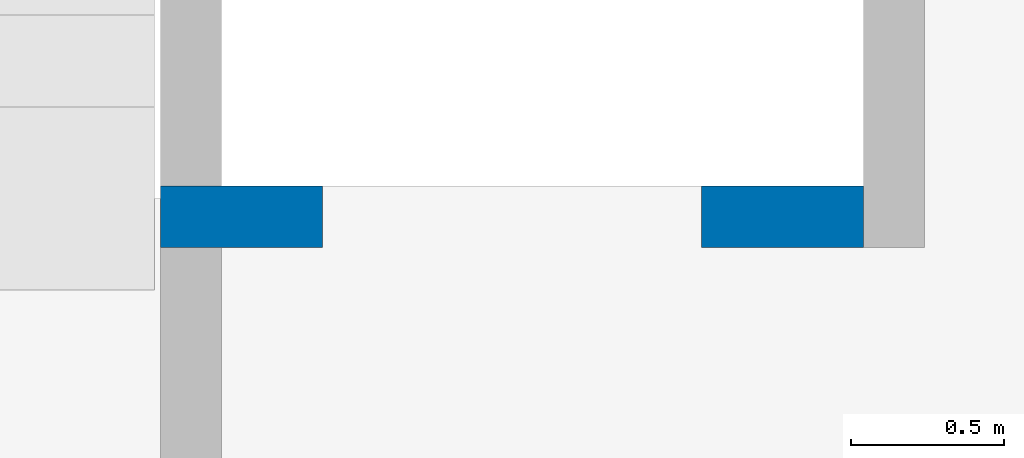
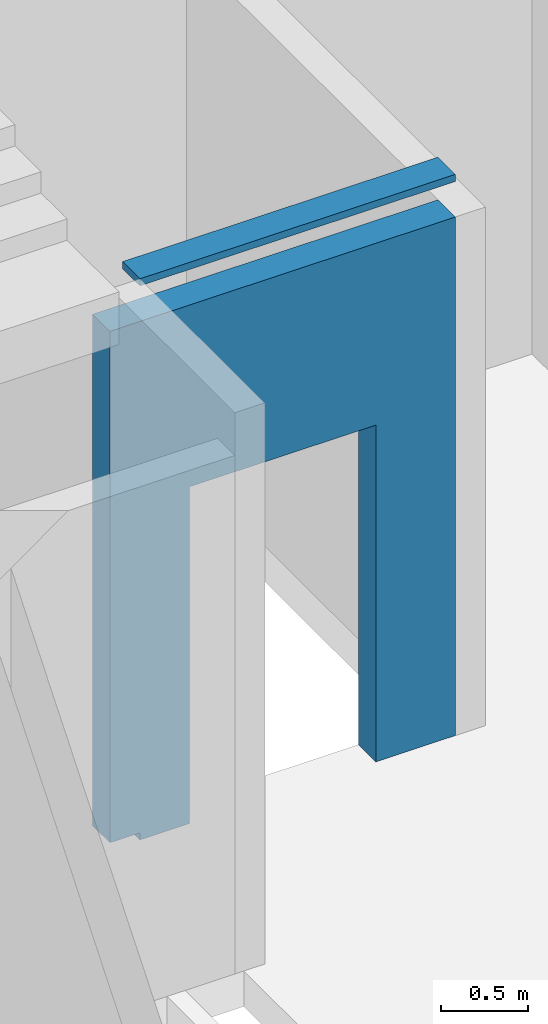
# One storey, part 93 of 93: 1 wall, 1 opening.
"""IFC4 building model written with IfcOpenShell, lengths in millimetres."""

from ifc_helpers import new_model, entity, si_unit, converted_unit, derived_unit, direction, frame, origin, place, context, subcontext, project, spatial, indexed_curve, outline, extrude, polygons, material, type_object, element, save


model = new_model("IFC4")

# Units and contexts
model_context = context("Model", 3, precision=0.01, world=origin(), true_north=direction((6.12303176911189e-17, 1.0)))
plan_context = context("Plan", 3, precision=0.01, world=origin(), true_north=direction((6.12303176911189e-17, 1.0)))
body_context = subcontext(model_context, "Body", "Model", "MODEL_VIEW")
ifc_project = project(units=[si_unit("LENGTHUNIT", "METRE", prefix="MILLI"), si_unit("AREAUNIT", "SQUARE_METRE"), si_unit("VOLUMEUNIT", "CUBIC_METRE"), converted_unit("PLANEANGLEUNIT", "DEGREE", entity("IfcRatioMeasure", 0.0174532925199433), si_unit("PLANEANGLEUNIT", "RADIAN"), dimensions=[0, 0, 0, 0, 0, 0, 0]), si_unit("MASSUNIT", "GRAM", prefix="KILO"), derived_unit("MASSDENSITYUNIT", [(si_unit("MASSUNIT", "GRAM", prefix="KILO"), 1), (si_unit("LENGTHUNIT", "METRE"), -3)]), derived_unit("MOMENTOFINERTIAUNIT", [(si_unit("LENGTHUNIT", "METRE"), 4)]), si_unit("TIMEUNIT", "SECOND"), si_unit("FREQUENCYUNIT", "HERTZ"), si_unit("THERMODYNAMICTEMPERATUREUNIT", "DEGREE_CELSIUS"), derived_unit("THERMALTRANSMITTANCEUNIT", [(si_unit("MASSUNIT", "GRAM", prefix="KILO"), 1), (si_unit("THERMODYNAMICTEMPERATUREUNIT", "KELVIN"), -1), (si_unit("TIMEUNIT", "SECOND"), -3)]), derived_unit("VOLUMETRICFLOWRATEUNIT", [(si_unit("LENGTHUNIT", "METRE"), 3), (si_unit("TIMEUNIT", "SECOND"), -1)]), derived_unit("MASSFLOWRATEUNIT", [(si_unit("MASSUNIT", "GRAM", prefix="KILO"), 1), (si_unit("TIMEUNIT", "SECOND"), -1)]), derived_unit("ROTATIONALFREQUENCYUNIT", [(si_unit("TIMEUNIT", "SECOND"), -1)]), si_unit("ELECTRICCURRENTUNIT", "AMPERE"), si_unit("ELECTRICVOLTAGEUNIT", "VOLT"), si_unit("POWERUNIT", "WATT"), si_unit("FORCEUNIT", "NEWTON", prefix="KILO"), si_unit("ILLUMINANCEUNIT", "LUX"), si_unit("LUMINOUSFLUXUNIT", "LUMEN"), si_unit("LUMINOUSINTENSITYUNIT", "CANDELA"), derived_unit("USERDEFINED", [(si_unit("MASSUNIT", "GRAM", prefix="KILO"), -1), (si_unit("LENGTHUNIT", "METRE"), -2), (si_unit("TIMEUNIT", "SECOND"), 3), (si_unit("LUMINOUSFLUXUNIT", "LUMEN"), 1)]), derived_unit("LINEARVELOCITYUNIT", [(si_unit("LENGTHUNIT", "METRE"), 1), (si_unit("TIMEUNIT", "SECOND"), -1)]), si_unit("PRESSUREUNIT", "PASCAL"), derived_unit("USERDEFINED", [(si_unit("LENGTHUNIT", "METRE"), -2), (si_unit("MASSUNIT", "GRAM", prefix="KILO"), 1), (si_unit("TIMEUNIT", "SECOND"), -2)]), derived_unit("LINEARFORCEUNIT", [(si_unit("MASSUNIT", "GRAM", prefix="KILO"), 1), (si_unit("LENGTHUNIT", "METRE"), 1), (si_unit("TIMEUNIT", "SECOND"), -2), (si_unit("LENGTHUNIT", "METRE"), -1)]), derived_unit("PLANARFORCEUNIT", [(si_unit("MASSUNIT", "GRAM", prefix="KILO"), 1), (si_unit("LENGTHUNIT", "METRE"), 1), (si_unit("TIMEUNIT", "SECOND"), -2), (si_unit("LENGTHUNIT", "METRE"), -2)])], contexts=[model_context, plan_context])

# Site, building, storey
site_placement = place(None, origin())
site = spatial("IfcSite", under=ifc_project, at=site_placement, CompositionType="ELEMENT")
building_placement = place(site_placement, origin())
building = spatial("IfcBuilding", under=site, at=building_placement, CompositionType="ELEMENT")
storey_placement = place(building_placement, frame((0.0, 0.0, 15900.0)))
storey = spatial("IfcBuildingStorey", under=building, at=storey_placement, CompositionType="ELEMENT", Elevation=15900.0)

# Wall, opening
ifc_material = material()
wall_type = type_object("IfcWallType", PredefinedType="STANDARD")
wall_placement = place(storey_placement, frame((71069.9994506836, 14369.9992263555, -150.0), z_axis=(0.0, 0.0, 1.0), x_axis=(-1.0, 0.0, 0.0)))
wall = element("IfcWall", 1, at=wall_placement, inside=storey, type_object=wall_type, material=ifc_material, PredefinedType="NOTDEFINED", context=body_context, shape_type="Tessellation", body=[
    polygons([(1769.99918212887, -100.000000000003, -2.16573425859679e-12), (2099.99918212886, -100.000000000003, -2.16573425859679e-12), (2099.99918212886, -100.000000000003, 49.9999999999995), (2299.99918212887, -100.000000000003, 49.9999999999995), (2299.99918212887, -100.000000000003, 3650.0), (2099.99918212887, -100.000000000001, 3650.0), (-2.4387927500343e-12, -100.000000000001, 3650.0), (-2.4387927500343e-12, -100.000000000001, -2.16573425859679e-12), (529.999182128873, -100.000000000001, -2.16573425859679e-12), (529.999182128864, -100.000000000001, 2369.99999999805), (1769.99918212887, -99.9999999999989, 2369.99999999804), (2099.99918212886, 99.9999999999989, -2.16573425859679e-12), (1769.99918212887, 99.9999999999989, -2.16573425859679e-12), (1769.99918212887, 99.9999999999989, 2369.99999999805), (529.999182128872, 99.9999999999989, 2369.99999999805), (529.999182128872, 99.9999999999989, -2.16573425859679e-12), (-3.00376710535355e-12, 99.9999999999968, -2.16573425859679e-12), (-3.00376710535355e-12, 99.9999999999968, 3650.0), (2099.99918212887, 99.9999999999989, 3650.0), (2299.99918212887, 99.9999999999989, 3650.0), (2299.99918212887, 99.9999999999989, 49.9999999999995), (2099.99918212886, 99.9999999999989, 49.9999999999995)], [[[1, 2, 3, 4, 5, 6, 7, 8, 9, 10, 11]], [[12, 13, 14, 15, 16, 17, 18, 19, 20, 21, 22]], [[8, 17, 16, 9]], [[17, 8, 7, 18]], [[10, 15, 14, 11]], [[11, 14, 13, 1]], [[15, 10, 9, 16]], [[4, 3, 22, 21]], [[5, 20, 19, 18, 7, 6]], [[3, 2, 12, 22]], [[5, 4, 21, 20]], [[2, 1, 13, 12]]], closed=True),
    polygons([(-2.4387927500343e-12, -100.000000000001, 3950.0), (2099.99918212886, -100.000000000003, 3950.0), (2099.99918212886, 99.9999999999989, 3950.0), (-3.00376710535355e-12, 99.9999999999968, 3950.0), (2099.99918212886, -100.000000000003, 3900.0), (2099.99918212886, 99.9999999999989, 3900.0), (-2.4387927500343e-12, -100.000000000001, 3900.0), (-3.00376710535355e-12, 99.9999999999968, 3900.0)], [[[1, 2, 3, 4]], [[3, 2, 5, 6]], [[5, 7, 8, 6]], [[1, 4, 8, 7]], [[4, 3, 6, 8]], [[2, 1, 7, 5]]], closed=True),
])
opening_placement = place(wall_placement, frame((71069.9994506836, 14369.9992263555, 150.0), z_axis=(0.0, 0.0, 1.0), x_axis=(-1.0, 0.0, 0.0)))
element("IfcOpeningElement", 2, at=opening_placement, cuts=wall, PredefinedType="OPENING", context=body_context, shape_type="SweptSolid", body=[
    extrude(outline(indexed_curve([(-619.999999999998, -1184.99999999902), (620.000000000006, -1184.99999999902), (620.000000000006, 1184.99999999902), (-619.999999999998, 1184.99999999902), (-619.999999999998, -1184.99999999902)], self_intersect=False)), frame((69920.0002685547, 14569.9992263574, 1035.0), z_axis=(0.0, -1.0, 0.0), x_axis=(-1.0, 0.0, 0.0)), (0.0, 0.0, 1.0), 400.000000001943),
])

save(model, "model.ifc")
